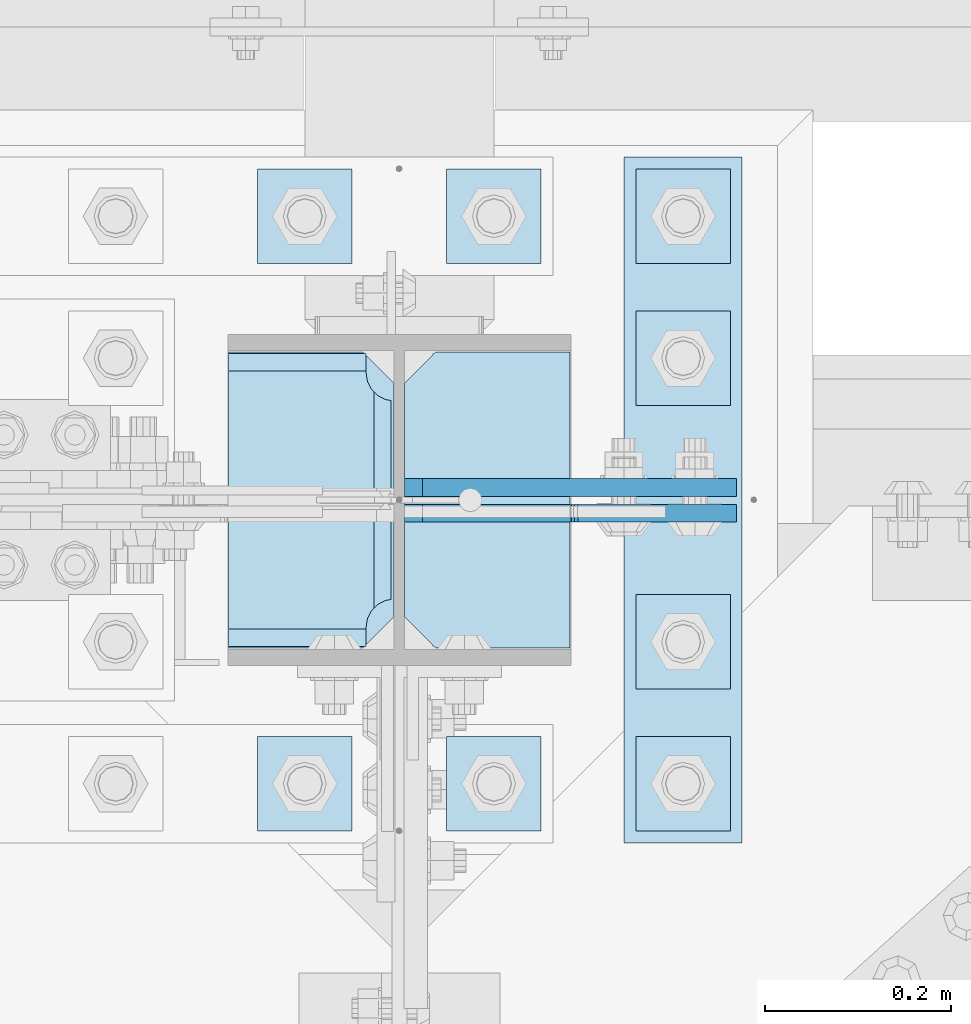
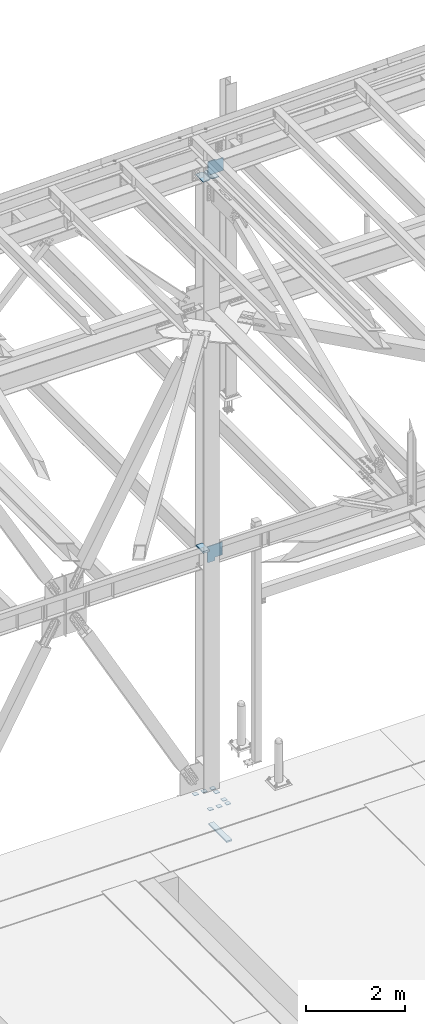
# One storey, part 3495 of 3843: 14 plates, 2 elements without a shape of their own.
"""IFC2X3 building model written with IfcOpenShell, lengths in millimetres."""

from ifc_helpers import new_model, si_unit, frame, origin_with_axes, place, context, subcontext, project, spatial, faceted_brep, material, type_object, element, aggregate, save


model = new_model("IFC2X3")

# Units and contexts
model_context = context("Model", 3, precision=1e-05, world=origin_with_axes())
body_context = subcontext(model_context, "Body", "Model", "MODEL_VIEW")
ifc_project = project(units=[si_unit("LENGTHUNIT", "METRE", prefix="MILLI"), si_unit("AREAUNIT", "SQUARE_METRE"), si_unit("VOLUMEUNIT", "CUBIC_METRE"), si_unit("MASSUNIT", "GRAM", prefix="KILO"), si_unit("TIMEUNIT", "SECOND"), si_unit("PLANEANGLEUNIT", "RADIAN"), si_unit("SOLIDANGLEUNIT", "STERADIAN"), si_unit("THERMODYNAMICTEMPERATUREUNIT", "DEGREE_CELSIUS"), si_unit("LUMINOUSINTENSITYUNIT", "LUMEN")], contexts=[model_context])

# Site, building, storey
site_placement = place(None, origin_with_axes())
site = spatial("IfcSite", under=ifc_project, at=site_placement, CompositionType="ELEMENT")
building_placement = place(site_placement, origin_with_axes())
building = spatial("IfcBuilding", under=site, at=building_placement, Name="Undefined", CompositionType="ELEMENT")
storey_placement = place(building_placement, origin_with_axes())
storey = spatial("IfcBuildingStorey", under=building, at=storey_placement, Name="Undefined", CompositionType="ELEMENT", Elevation=0.0)

# Assembly, plates
assembly_1_placement = place(storey_placement, origin_with_axes())
assembly_1 = element("IfcElementAssembly", 1, at=assembly_1_placement, inside=storey, Name="COLUMN", AssemblyPlace="NOTDEFINED", PredefinedType="RIGID_FRAME")
ifc_material = material(Name="STEEL/A572-50")
plate_type_1 = type_object("IfcPlateType", PredefinedType="NOTDEFINED")
plate_1_placement = place(assembly_1_placement, frame((62453.04375, 92375.0375, 36420.425), z_axis=(0.0, -1.0, 0.0), x_axis=(1.0, 0.0, 0.0)))
plate_1 = element("IfcPlate", 2, at=plate_1_placement, type_object=plate_type_1, material=ifc_material, Name="PLATE", context=body_context, shape_type="Brep", body=[
    faceted_brep([(160.070927103505, 9.33329077896633, 48.2144734940957), (156.294129000915, 15.875, 44.437675391513), (156.294129000915, 15.875, 276.23732460849), (160.070927103505, 9.33329077896633, 272.460526505907), (168.479274789282, -5.23062396988826, 268.176259371801), (174.625000047687, -15.875, 267.202872116366), (174.625000047687, -15.875, 53.4721278836369), (168.479274789282, -5.23062396988826, 52.4987406282016), (147.63749961853, 15.875, 21.5053709990898), (147.63749961853, -15.875, 3.17449995232164), (0.0, -15.875, 3.17449995232164), (0.0, 15.875, 21.5053709990898), (0.0, 15.875, 299.168629000924), (0.0, -15.875, 317.499500047692), (147.63749961853, -15.875, 317.499500047692), (147.63749961853, 15.875, 299.168629000924), (147.63749961853, -15.875, 296.862501907352), (147.63749961853, 15.875, 296.862501907352), (149.113757464445, -15.875, 287.541776696642), (149.113757464445, 15.875, 287.541776696642), (153.398024598548, -15.875, 279.133429010864), (153.398024598548, 15.875, 279.133429010864), (160.070927103505, -15.875, 272.460526505907), (168.479274789282, -15.875, 268.176259371801), (168.479274789282, -15.875, 52.4987406282016), (160.070927103505, -15.875, 48.2144734940957), (153.398024598548, -15.875, 41.5415709891386), (153.398024598548, 15.875, 41.5415709891386), (149.113757464449, -15.875, 33.1332233033609), (149.113757464449, 15.875, 33.1332233033609), (147.63749961853, -15.875, 23.8124980926514), (147.63749961853, 15.875, 23.8124980926514)], [[[0, 1, 2, 3, 4, 5, 6, 7]], [[8, 9, 10, 11]], [[12, 13, 14, 15]], [[13, 12, 11, 10]], [[16, 17, 15, 14]], [[16, 18, 19, 17]], [[18, 20, 21, 19]], [[21, 20, 22, 3, 2]], [[22, 23, 4, 3]], [[23, 5, 4]], [[24, 7, 6]], [[24, 25, 0, 7]], [[25, 26, 27, 1, 0]], [[26, 28, 29, 27]], [[28, 30, 31, 29]], [[31, 30, 9, 8]], [[27, 29, 31, 8, 11, 12, 15, 17, 19, 21, 2, 1]], [[9, 30, 28, 26, 25, 24, 6, 5, 23, 22, 20, 18, 16, 14, 13, 10]]]),
])
plate_type_2 = type_object("IfcPlateType", PredefinedType="NOTDEFINED")
plate_2_placement = place(assembly_1_placement, frame((62819.75625, 92055.95, 45603.9146479385), z_axis=(0.0, 1.0, 0.0), x_axis=(-1.0, 0.0, 0.0)))
plate_2 = element("IfcPlate", 3, at=plate_2_placement, type_object=plate_type_2, material=ifc_material, Name="PLATE", context=body_context, shape_type="Brep", body=[
    faceted_brep([(0.0, -9.52500000000146, 0.0), (0.0, -9.52500000000146, 317.5), (0.0, 9.52500000000146, 317.5), (0.0, 9.52500000000146, 0.0), (144.462501525879, -9.52500000000146, 317.5), (144.462501525879, 9.52500000000146, 317.5), (177.800003051758, -9.52500000000146, 284.162498474121), (177.800003051758, 9.52500000000146, 284.162498474121), (177.800003051758, -9.52500000000146, 33.3375015258789), (177.800003051758, 9.52500000000146, 33.3375015258789), (144.462501525879, -9.52500000000146, 0.0), (144.462501525879, 9.52500000000146, 0.0)], [[[0, 1, 2, 3]], [[1, 4, 5, 2]], [[4, 6, 7, 5]], [[6, 8, 9, 7]], [[8, 10, 11, 9]], [[10, 0, 3, 11]], [[5, 7, 9, 11, 3, 2]], [[10, 8, 6, 4, 1, 0]]]),
])
plate_3_placement = place(assembly_1_placement, frame((62453.0437499977, 92373.45, 45592.4102004823), z_axis=(0.0, -1.0, 0.0), x_axis=(1.0, 0.0, 0.0)))
plate_3 = element("IfcPlate", 4, at=plate_3_placement, type_object=plate_type_2, material=ifc_material, Name="PLATE", context=body_context, shape_type="Brep", body=[
    faceted_brep([(0.0, -9.52500000000146, 0.0), (0.0, -9.52500000000146, 317.5), (0.0, 9.52500000000146, 317.5), (0.0, 9.52500000000146, 0.0), (144.462501525879, -9.52500000000146, 317.5), (144.462501525879, 9.52500000000146, 317.5), (177.800003051758, -9.52500000000146, 284.162498474121), (177.800003051758, 9.52500000000146, 284.162498474121), (177.800003051758, -9.52500000000146, 33.3375015258789), (177.800003051758, 9.52500000000146, 33.3375015258789), (144.462501525879, -9.52500000000146, 0.0), (144.462501525879, 9.52500000000146, 0.0)], [[[0, 1, 2, 3]], [[1, 4, 5, 2]], [[4, 6, 7, 5]], [[6, 8, 9, 7]], [[8, 10, 11, 9]], [[10, 0, 3, 11]], [[5, 7, 9, 11, 3, 2]], [[10, 8, 6, 4, 1, 0]]]),
])

assembly_2_placement = place(storey_placement, origin_with_axes())
assembly_2 = element("IfcElementAssembly", 5, at=assembly_2_placement, inside=storey, Name="TEMPLATE", AssemblyPlace="NOTDEFINED", PredefinedType="RIGID_FRAME")
plate_type_3 = type_object("IfcPlateType", PredefinedType="NOTDEFINED")
plate_4_placement = place(assembly_2_placement, frame((62585.6, 91960.7, 30143.45), z_axis=(-1.0, 0.0, 0.0), x_axis=(0.0, -1.0, 0.0)))
plate_4 = element("IfcPlate", 6, at=plate_4_placement, type_object=plate_type_3, material=ifc_material, Name="Washer Plate", context=body_context, shape_type="Brep", body=[
    faceted_brep([(0.0, -6.3499999046162, 0.0), (-1.67347025126219e-10, -6.35000000000582, 101.600000000151), (-1.67347025126219e-10, 6.35000000000582, 101.600000000151), (7.27595761418343e-12, 6.3499999046162, 0.0), (101.599998474121, -6.34999999999854, 101.599998474121), (101.599998474121, 6.34999999999854, 101.599998474121), (101.6, -6.34999999999854, 0.0), (101.6, 6.34999999999854, 0.0)], [[[0, 1, 2, 3]], [[1, 4, 5, 2]], [[4, 6, 7, 5]], [[6, 0, 3, 7]], [[5, 7, 3, 2]], [[6, 4, 1, 0]]]),
])
plate_5_placement = place(assembly_2_placement, frame((62788.8, 91960.7, 30143.45), z_axis=(-1.0, 0.0, 0.0), x_axis=(0.0, -1.0, 0.0)))
plate_5 = element("IfcPlate", 7, at=plate_5_placement, type_object=plate_type_3, material=ifc_material, Name="Washer Plate", context=body_context, shape_type="Brep", body=[
    faceted_brep([(0.0, -6.3499999046162, 0.0), (-1.67347025126219e-10, -6.35000000000582, 101.600000000151), (-1.67347025126219e-10, 6.35000000000582, 101.600000000151), (7.27595761418343e-12, 6.3499999046162, 0.0), (101.599998474121, -6.34999999999854, 101.599998474121), (101.599998474121, 6.34999999999854, 101.599998474121), (101.6, -6.34999999999854, 0.0), (101.6, 6.34999999999854, 0.0)], [[[0, 1, 2, 3]], [[1, 4, 5, 2]], [[4, 6, 7, 5]], [[6, 0, 3, 7]], [[5, 7, 3, 2]], [[6, 4, 1, 0]]]),
])
plate_6_placement = place(assembly_2_placement, frame((62992.0, 91960.7, 30143.45), z_axis=(-1.0, 0.0, 0.0), x_axis=(0.0, -1.0, 0.0)))
plate_6 = element("IfcPlate", 8, at=plate_6_placement, type_object=plate_type_3, material=ifc_material, Name="Washer Plate", context=body_context, shape_type="Brep", body=[
    faceted_brep([(0.0, -6.3499999046162, 0.0), (-1.67347025126219e-10, -6.35000000000582, 101.600000000151), (-1.67347025126219e-10, 6.35000000000582, 101.600000000151), (7.27595761418343e-12, 6.3499999046162, 0.0), (101.599998474121, -6.34999999999854, 101.599998474121), (101.599998474121, 6.34999999999854, 101.599998474121), (101.6, -6.34999999999854, 0.0), (101.6, 6.34999999999854, 0.0)], [[[0, 1, 2, 3]], [[1, 4, 5, 2]], [[4, 6, 7, 5]], [[6, 0, 3, 7]], [[5, 7, 3, 2]], [[6, 4, 1, 0]]]),
])
plate_7_placement = place(assembly_2_placement, frame((62992.0, 92113.1, 30143.45), z_axis=(-1.0, 0.0, 0.0), x_axis=(0.0, -1.0, 0.0)))
plate_7 = element("IfcPlate", 9, at=plate_7_placement, type_object=plate_type_3, material=ifc_material, Name="Washer Plate", context=body_context, shape_type="Brep", body=[
    faceted_brep([(0.0, -6.3499999046162, 0.0), (-1.67347025126219e-10, -6.35000000000582, 101.600000000151), (-1.67347025126219e-10, 6.35000000000582, 101.600000000151), (7.27595761418343e-12, 6.3499999046162, 0.0), (101.599998474121, -6.34999999999854, 101.599998474121), (101.599998474121, 6.34999999999854, 101.599998474121), (101.6, -6.34999999999854, 0.0), (101.6, 6.34999999999854, 0.0)], [[[0, 1, 2, 3]], [[1, 4, 5, 2]], [[4, 6, 7, 5]], [[6, 0, 3, 7]], [[5, 7, 3, 2]], [[6, 4, 1, 0]]]),
])
plate_8_placement = place(assembly_2_placement, frame((62992.0, 92417.9, 30143.45), z_axis=(-1.0, 0.0, 0.0), x_axis=(0.0, -1.0, 0.0)))
plate_8 = element("IfcPlate", 10, at=plate_8_placement, type_object=plate_type_3, material=ifc_material, Name="Washer Plate", context=body_context, shape_type="Brep", body=[
    faceted_brep([(0.0, -6.3499999046162, 0.0), (-1.67347025126219e-10, -6.35000000000582, 101.600000000151), (-1.67347025126219e-10, 6.35000000000582, 101.600000000151), (7.27595761418343e-12, 6.3499999046162, 0.0), (101.599998474121, -6.34999999999854, 101.599998474121), (101.599998474121, 6.34999999999854, 101.599998474121), (101.6, -6.34999999999854, 0.0), (101.6, 6.34999999999854, 0.0)], [[[0, 1, 2, 3]], [[1, 4, 5, 2]], [[4, 6, 7, 5]], [[6, 0, 3, 7]], [[5, 7, 3, 2]], [[6, 4, 1, 0]]]),
])
plate_9_placement = place(assembly_2_placement, frame((62585.6, 92570.3, 30143.45), z_axis=(-1.0, 0.0, 0.0), x_axis=(0.0, -1.0, 0.0)))
plate_9 = element("IfcPlate", 11, at=plate_9_placement, type_object=plate_type_3, material=ifc_material, Name="Washer Plate", context=body_context, shape_type="Brep", body=[
    faceted_brep([(0.0, -6.3499999046162, 0.0), (-1.67347025126219e-10, -6.35000000000582, 101.600000000151), (-1.67347025126219e-10, 6.35000000000582, 101.600000000151), (7.27595761418343e-12, 6.3499999046162, 0.0), (101.599998474121, -6.34999999999854, 101.599998474121), (101.599998474121, 6.34999999999854, 101.599998474121), (101.6, -6.34999999999854, 0.0), (101.6, 6.34999999999854, 0.0)], [[[0, 1, 2, 3]], [[1, 4, 5, 2]], [[4, 6, 7, 5]], [[6, 0, 3, 7]], [[5, 7, 3, 2]], [[6, 4, 1, 0]]]),
])
plate_10_placement = place(assembly_2_placement, frame((62788.8, 92570.3, 30143.45), z_axis=(-1.0, 0.0, 0.0), x_axis=(0.0, -1.0, 0.0)))
plate_10 = element("IfcPlate", 12, at=plate_10_placement, type_object=plate_type_3, material=ifc_material, Name="Washer Plate", context=body_context, shape_type="Brep", body=[
    faceted_brep([(0.0, -6.3499999046162, 0.0), (-1.67347025126219e-10, -6.35000000000582, 101.600000000151), (-1.67347025126219e-10, 6.35000000000582, 101.600000000151), (7.27595761418343e-12, 6.3499999046162, 0.0), (101.599998474121, -6.34999999999854, 101.599998474121), (101.599998474121, 6.34999999999854, 101.599998474121), (101.6, -6.34999999999854, 0.0), (101.6, 6.34999999999854, 0.0)], [[[0, 1, 2, 3]], [[1, 4, 5, 2]], [[4, 6, 7, 5]], [[6, 0, 3, 7]], [[5, 7, 3, 2]], [[6, 4, 1, 0]]]),
])
plate_11_placement = place(assembly_2_placement, frame((62992.0, 92570.3, 30143.45), z_axis=(-1.0, 0.0, 0.0), x_axis=(0.0, -1.0, 0.0)))
plate_11 = element("IfcPlate", 13, at=plate_11_placement, type_object=plate_type_3, material=ifc_material, Name="Washer Plate", context=body_context, shape_type="Brep", body=[
    faceted_brep([(0.0, -6.3499999046162, 0.0), (-1.67347025126219e-10, -6.35000000000582, 101.600000000151), (-1.67347025126219e-10, 6.35000000000582, 101.600000000151), (7.27595761418343e-12, 6.3499999046162, 0.0), (101.599998474121, -6.34999999999854, 101.599998474121), (101.599998474121, 6.34999999999854, 101.599998474121), (101.6, -6.34999999999854, 0.0), (101.6, 6.34999999999854, 0.0)], [[[0, 1, 2, 3]], [[1, 4, 5, 2]], [[4, 6, 7, 5]], [[6, 0, 3, 7]], [[5, 7, 3, 2]], [[6, 4, 1, 0]]]),
])

# Plate
plate_type_4 = type_object("IfcPlateType", PredefinedType="NOTDEFINED")
plate_12_placement = place(assembly_1_placement, frame((62641.95625, 92228.1937503815, 36020.375), z_axis=(0.707106781186548, 0.0, 0.707106781186548), x_axis=(0.707106781186548, 0.0, -0.707106781186548)))
plate_12 = element("IfcPlate", 14, at=plate_12_placement, type_object=plate_type_4, material=ifc_material, Name="PLATE", context=body_context, shape_type="Brep", body=[
    faceted_brep([(0.0, -9.52500000000146, 0.0), (-258.182363479493, -9.52499999999418, 258.182363479486), (-258.182363479493, 9.52499999999418, 258.182363479486), (0.0, 9.52500000000146, 0.0), (-258.182363479496, -9.52499999999418, 285.123131842571), (-258.182363479496, 9.52499999999418, 285.123131842571), (-19.6443102647499, -9.52499999999418, 523.66118505731), (-19.6443102647499, 9.52499999999418, 523.66118505731), (204.862092760904, -9.52499999999418, 299.154782031677), (204.862092760904, 9.52499999999418, 299.154782031677), (88.1187630527165, -9.52499999999418, 182.411452323489), (88.1187630527165, 9.52499999999418, 182.411452323489), (85.3657491522463, -9.52499999999418, 178.291275855343), (85.3657491522463, 9.52499999999418, 178.291275855343), (84.3990192296587, -9.52499999999418, 173.431196337304), (84.3990192296587, 9.52499999999418, 173.431196337304), (85.3657491522499, -9.52499999999418, 168.571116819279), (85.3657491522499, 9.52499999999418, 168.571116819279), (88.1187630527165, -9.52499999999418, 164.450940351133), (88.1187630527165, 9.52499999999418, 164.450940351133), (139.755236456211, -9.52500000000146, 112.814466211697), (139.755236456211, 9.52500000000146, 112.814466211697), (26.9407683632344, -9.52499999999964, 2.03726813197136e-10), (26.9407683632344, 9.52499999999964, 2.03726813197136e-10)], [[[0, 1, 2, 3]], [[1, 4, 5, 2]], [[4, 6, 7, 5]], [[6, 8, 9, 7]], [[8, 10, 11, 9]], [[10, 12, 13, 11]], [[12, 14, 15, 13]], [[14, 16, 17, 15]], [[16, 18, 19, 17]], [[18, 20, 21, 19]], [[20, 22, 23, 21]], [[22, 0, 3, 23]], [[5, 7, 9, 11, 13, 15, 17, 19, 21, 23, 3, 2]], [[22, 20, 18, 16, 14, 12, 10, 8, 6, 4, 1, 0]]]),
])

plate_type_5 = type_object("IfcPlateType", PredefinedType="NOTDEFINED")
plate_13_placement = place(assembly_1_placement, frame((62641.95625, 92200.4124996185, 45632.4896479126), z_axis=(0.707106781186548, 0.0, 0.707106781186548), x_axis=(0.707106781186548, 0.0, -0.707106781186548)))
plate_13 = element("IfcPlate", 15, at=plate_13_placement, type_object=plate_type_5, material=ifc_material, Name="PLATE", context=body_context, shape_type="Brep", body=[
    faceted_brep([(0.0, -9.52500000000146, 0.0), (-209.979301496754, -9.52500000000146, 209.979301496671), (-209.979301496754, 9.52500000000146, 209.979301496671), (0.0, 9.52500000000146, 0.0), (-209.979301496471, -9.52500000000146, 236.920069860033), (-209.979301496471, 9.52500000000146, 236.920069860033), (-97.1648339737767, -9.52500000000146, 349.734537382756), (-97.1648339737767, 9.52500000000146, 349.734537382756), (-93.3396839560301, -9.52500000000146, 345.909387365013), (-93.3396839560301, 9.52500000000146, 345.909387365013), (-89.219507487891, -9.52500000000146, 343.156373464546), (-89.219507487891, 9.52500000000146, 343.156373464546), (-84.35942796983, -9.52500000000146, 342.189643541991), (-84.35942796983, 9.52500000000146, 342.189643541991), (-79.4993484517727, -9.52500000000146, 343.15637346459), (-79.4993484517727, 9.52500000000146, 343.15637346459), (-75.3791719835863, -9.52500000000146, 345.909387365115), (-75.3791719835863, 9.52500000000146, 345.909387365115), (41.3641577270682, -9.52500000000146, 462.652717075805), (41.3641577270682, 9.52500000000146, 462.652717075805), (265.870560752759, -9.52500000000146, 238.146314050202), (265.870560752759, 9.52500000000146, 238.146314050202), (26.9407683632344, -9.52499999999964, 2.03726813197136e-10), (26.9407683632344, 9.52499999999964, 2.03726813197136e-10)], [[[0, 1, 2, 3]], [[1, 4, 5, 2]], [[4, 6, 7, 5]], [[6, 8, 9, 7]], [[8, 10, 11, 9]], [[10, 12, 13, 11]], [[12, 14, 15, 13]], [[14, 16, 17, 15]], [[16, 18, 19, 17]], [[18, 20, 21, 19]], [[20, 22, 23, 21]], [[22, 0, 3, 23]], [[5, 7, 9, 11, 13, 15, 17, 19, 21, 23, 3, 2]], [[22, 20, 18, 16, 14, 12, 10, 8, 6, 4, 1, 0]]]),
])

aggregate(assembly_1, [plate_2, plate_13, plate_3, plate_12, plate_1])

plate_type_6 = type_object("IfcPlateType", PredefinedType="NOTDEFINED")
plate_14_placement = place(assembly_2_placement, frame((62877.7, 92583.0, 29241.75), z_axis=(1.0, 0.0, 0.0), x_axis=(0.0, -1.0, 0.0)))
plate_14 = element("IfcPlate", 16, at=plate_14_placement, type_object=plate_type_6, material=ifc_material, Name="PLATE", context=body_context, shape_type="Brep", body=[
    faceted_brep([(0.0, -19.0500000000029, 0.0), (0.0, -19.0499999999993, 127.0), (0.0, 19.0499999999993, 127.0), (0.0, 19.0500000000029, 0.0), (736.599975585938, -19.0499999999993, 127.0), (736.599975585938, 19.0499999999993, 127.0), (736.599975585938, -19.0499999999993, 0.0), (736.599975585938, 19.0499999999993, 0.0)], [[[0, 1, 2, 3]], [[1, 4, 5, 2]], [[4, 6, 7, 5]], [[6, 0, 3, 7]], [[5, 7, 3, 2]], [[6, 4, 1, 0]]]),
])

aggregate(assembly_2, [plate_14, plate_4, plate_5, plate_6, plate_7, plate_8, plate_9, plate_10, plate_11])

save(model, "model.ifc")
